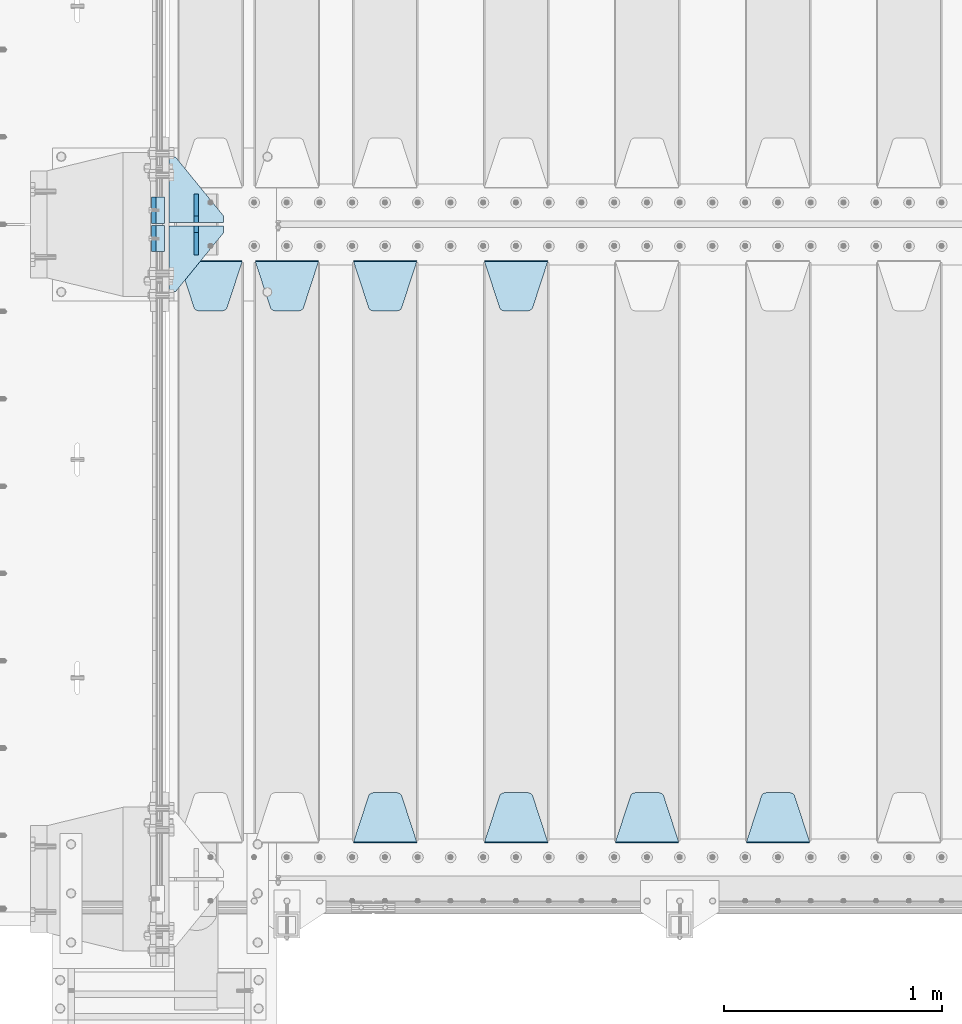
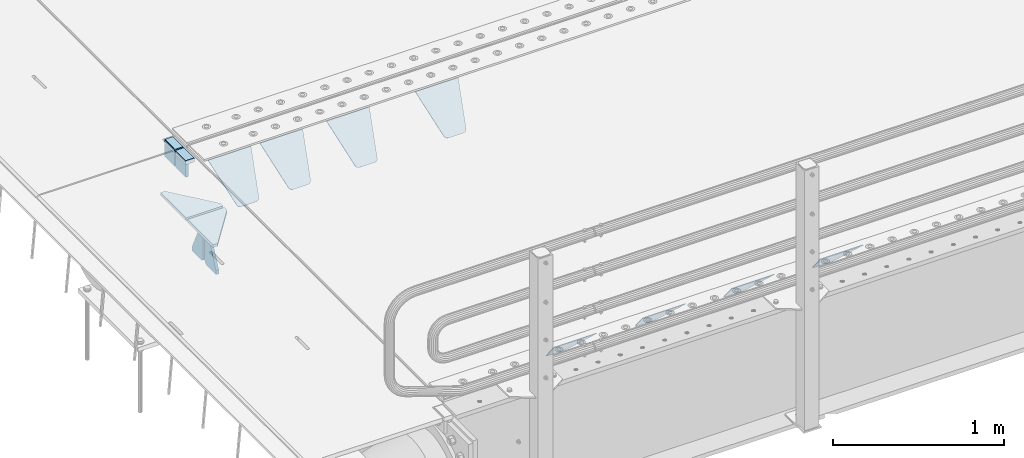
# One storey, part 191 of 240: 16 plates.
"""IFC2X3 building model written with IfcOpenShell, lengths in millimetres."""

from ifc_helpers import new_model, si_unit, frame, origin_with_axes, place, context, subcontext, project, spatial, faceted_brep, material, type_object, element, save


model = new_model("IFC2X3")

# Units and contexts
model_context = context("Model", 3, precision=1e-05, world=origin_with_axes())
body_context = subcontext(model_context, "Body", "Model", "MODEL_VIEW")
ifc_project = project(units=[si_unit("LENGTHUNIT", "METRE", prefix="MILLI"), si_unit("AREAUNIT", "SQUARE_METRE"), si_unit("VOLUMEUNIT", "CUBIC_METRE"), si_unit("MASSUNIT", "GRAM", prefix="KILO"), si_unit("TIMEUNIT", "SECOND"), si_unit("PLANEANGLEUNIT", "RADIAN"), si_unit("SOLIDANGLEUNIT", "STERADIAN"), si_unit("THERMODYNAMICTEMPERATUREUNIT", "DEGREE_CELSIUS"), si_unit("LUMINOUSINTENSITYUNIT", "LUMEN")], contexts=[model_context])

# Site, building, storey
site_placement = place(None, origin_with_axes())
site = spatial("IfcSite", under=ifc_project, at=site_placement, CompositionType="ELEMENT")
building_placement = place(site_placement, origin_with_axes())
building = spatial("IfcBuilding", under=site, at=building_placement, Name="Standard", CompositionType="ELEMENT")
storey_placement = place(building_placement, origin_with_axes())
storey = spatial("IfcBuildingStorey", under=building, at=storey_placement, Name="Undefined", CompositionType="ELEMENT", Elevation=0.0)

# Plates
ifc_material_1 = material()
plate_type_1 = type_object("IfcPlateType", PredefinedType="NOTDEFINED")
plate_1_placement = place(storey_placement, frame((42440.0, 26935.0, -16.0001127571065), z_axis=(-1.0, 0.0, 0.0), x_axis=(0.0, 0.0, 1.0)))
element("IfcPlate", 1, at=plate_1_placement, inside=storey, type_object=plate_type_1, material=ifc_material_1, context=body_context, shape_type="Brep", body=[
    faceted_brep([(3.5527136788005e-15, -60.0, 0.0), (2.49929144047201e-09, -60.0, 60.0), (2.49929144047201e-09, 60.0000000000036, 60.0), (0.0, 60.0000000000036, -7.27595761418343e-12), (25.0146748218828, -59.9999999999964, 60.0), (25.0146748218828, 60.0, 60.0), (26.5597449794466, -60.0, 59.7552873949098), (26.5597449794466, 60.0000000000036, 59.7552873949098), (27.9535758796897, -59.9999999999964, 59.0451032832789), (27.9535758796897, 60.0000000000036, 59.0451032832789), (29.0597323263517, -60.0, 57.9389640667287), (29.0597323263517, 60.0, 57.9389640667287), (29.7699381491534, -59.9999999999964, 56.5451442289705), (29.7699381491534, 60.0000000000036, 56.5451442289705), (30.0146748212763, -60.0, 55.0000778834001), (30.0146748212763, 60.0, 55.0000778834001), (30.0154536553013, -59.9999999999964, 5.00007788340736), (30.0154536553013, 60.0000000000036, 5.00007788340736), (29.7707554908505, -59.9999999999964, 3.45497428546514), (29.7707554908505, 60.0000000000036, 3.45497428546514), (29.0605660948355, -59.9999999999964, 2.06111154406972), (29.0605660948355, 60.0000000000036, 2.06111154406972), (27.9544051209123, -59.9999999999964, 0.954933339693525), (27.9544051209123, 60.0000000000036, 0.954933339693525), (26.5605534420796, -59.9999999999964, 0.244722232011554), (26.5605534420796, 60.0000000000036, 0.244722232011554), (25.0154536559091, -60.0, 7.27595761418343e-12), (25.0154536559091, 60.0, 7.27595761418343e-12)], [[[0, 1, 2, 3]], [[1, 4, 5, 2]], [[4, 6, 7, 5]], [[6, 8, 9, 7]], [[8, 10, 11, 9]], [[10, 12, 13, 11]], [[12, 14, 15, 13]], [[14, 16, 17, 15]], [[16, 18, 19, 17]], [[18, 20, 21, 19]], [[20, 22, 23, 21]], [[22, 24, 25, 23]], [[24, 26, 27, 25]], [[26, 0, 3, 27]], [[5, 7, 9, 11, 13, 15, 17, 19, 21, 23, 25, 27, 3, 2]], [[26, 24, 22, 20, 18, 16, 14, 12, 10, 8, 6, 4, 1, 0]]]),
])
plate_2_placement = place(storey_placement, frame((42439.99999994, 27065.0000004521, -16.0146144413882), z_axis=(-1.0, 0.0, 0.0), x_axis=(0.0, -4.95099997756316e-06, 0.999999999987744)))
element("IfcPlate", 2, at=plate_2_placement, inside=storey, type_object=plate_type_1, material=ifc_material_1, context=body_context, shape_type="Brep", body=[
    faceted_brep([(3.5527136788005e-15, -60.0, 0.0), (-0.000933120085687023, -60.0000000000036, 60.0), (-0.000933120085687023, 60.0, 59.9999999999927), (0.0, 60.0000000000036, -7.27595761418343e-12), (24.9991450303709, -60.0, 60.0), (24.9991450303709, 59.9999999999964, 59.9999999999927), (26.544215218168, -60.0000000000036, 59.7552873850873), (26.544215218168, 60.0, 59.75528738508), (27.9380461396139, -60.0, 59.0451032459096), (27.9380461396139, 60.0, 59.0451032459096), (29.0442025908961, -60.0, 57.9389639895744), (29.0442025908961, 60.0, 57.9389639895744), (29.7544083969366, -60.0, 56.5451441080368), (29.7544083969366, 60.0000000000036, 56.5451441080295), (29.9991450297669, -60.0000000000036, 55.0000777244568), (29.9991450297669, 60.0, 55.0000777244495), (29.999922274335, -60.0, 5.00007772445679), (29.999922274335, 60.0, 5.00007772444951), (29.7552240705896, -60.0000000000036, 3.45497416452417), (29.7552240705896, 60.0, 3.45497416452417), (29.0450346578116, -60.0, 2.06111146690819), (29.0450346578116, 60.0, 2.06111146690819), (27.9388736885073, -60.0, 0.954933302316931), (27.9388736885072, 59.9999999999964, 0.954933302316931), (26.5450220308766, -60.0000000000036, 0.244722222181736), (26.5450220308766, 60.0, 0.244722222181736), (24.9999222749392, -59.9999999999964, 0.0), (24.9999222749392, 60.0, -7.27595761418343e-12)], [[[0, 1, 2, 3]], [[1, 4, 5, 2]], [[4, 6, 7, 5]], [[6, 8, 9, 7]], [[8, 10, 11, 9]], [[10, 12, 13, 11]], [[12, 14, 15, 13]], [[14, 16, 17, 15]], [[16, 18, 19, 17]], [[18, 20, 21, 19]], [[20, 22, 23, 21]], [[22, 24, 25, 23]], [[24, 26, 27, 25]], [[26, 0, 3, 27]], [[5, 7, 9, 11, 13, 15, 17, 19, 21, 23, 25, 27, 3, 2]], [[26, 24, 22, 20, 18, 16, 14, 12, 10, 8, 6, 4, 1, 0]]]),
])
ifc_material_2 = material(Name="STEEL/S355N")
plate_type_2 = type_object("IfcPlateType", PredefinedType="NOTDEFINED")
plate_3_placement = place(storey_placement, frame((42390.0, 26995.0000855346, -105.984447297247), z_axis=(0.0, -1.0, 0.0), x_axis=(0.0, 0.0, 1.0)))
element("IfcPlate", 3, at=plate_3_placement, inside=storey, type_object=plate_type_2, material=ifc_material_2, context=body_context, shape_type="Brep", body=[
    faceted_brep([(0.0, -10.0, 0.0), (5.70725632087488e-07, -10.0, 119.999999999993), (5.70725632087488e-07, 10.0, 119.999999999993), (0.0, 10.0, 0.0), (89.9845046997066, -10.0, 119.999999999996), (89.9845046997066, 10.0, 119.999999999996), (89.9843902587891, -10.0, 6.18456397205591e-11), (89.9843902587891, 10.0, 6.18456397205591e-11)], [[[0, 1, 2, 3]], [[1, 4, 5, 2]], [[4, 6, 7, 5]], [[6, 0, 3, 7]], [[5, 7, 3, 2]], [[6, 4, 1, 0]]]),
])
plate_4_placement = place(storey_placement, frame((42390.0, 27125.000446002, -106.014939471591), z_axis=(0.0, -0.999999999987744, -4.95099999993769e-06), x_axis=(0.0, -4.95099997756316e-06, 0.999999999987744)))
element("IfcPlate", 4, at=plate_4_placement, inside=storey, type_object=plate_type_2, material=ifc_material_2, context=body_context, shape_type="Brep", body=[
    faceted_brep([(0.0, -10.0, 0.0), (5.70725632087488e-07, -10.0, 119.999999999993), (5.70725632087488e-07, 10.0, 119.999999999993), (0.0, 10.0, 0.0), (89.9999999999979, -10.0, 120.0), (89.9999999999979, 10.0, 120.0), (90.0, -10.0, 1.09139364212751e-11), (90.0, 10.0, 1.09139364212751e-11)], [[[0, 1, 2, 3]], [[1, 4, 5, 2]], [[4, 6, 7, 5]], [[6, 0, 3, 7]], [[5, 7, 3, 2]], [[6, 4, 1, 0]]]),
])
plate_type_3 = type_object("IfcPlateType", PredefinedType="NOTDEFINED")
plate_5_placement = place(storey_placement, frame((45395.0, 24168.232233047, -1.76776695296758), z_axis=(0.0, 0.707106781186547, -0.707106781186548), x_axis=(-1.0, 0.0, 0.0)))
element("IfcPlate", 5, at=plate_5_placement, inside=storey, type_object=plate_type_3, material=ifc_material_2, context=body_context, shape_type="Brep", body=[
    faceted_brep([(0.0, -2.5, 0.0), (69.345504679477, -2.50000000000364, 300.171731424827), (69.345504679477, 2.49999999999636, 300.171731424827), (0.0, 2.5, 0.0), (70.927406119954, -2.50000000000364, 304.897442415397), (70.927406119954, 2.49999999999636, 304.897442415397), (73.3818627772271, -2.50000000000728, 309.234538108525), (73.3818627772271, 2.49999999999636, 309.234538108529), (76.6187032999587, -2.50000000000728, 313.023683126099), (76.6187032999587, 2.49999999999636, 313.023683126103), (80.5190132705029, -2.50000000000364, 316.125672595368), (80.5190132705029, 2.49999999999636, 316.125672595368), (84.9395038596849, -2.50000000000364, 318.426546230472), (84.9395038596849, 2.49999999999636, 318.426546230472), (89.7177759439219, -2.5, 319.841774983277), (89.7177759439219, 2.49999999999636, 319.841774983273), (94.6782862926484, -2.50000000000364, 320.319366455074), (94.6782862926484, 2.49999999999636, 320.319366455074), (195.321713707352, -2.50000000000364, 320.319366455074), (195.321713707352, 2.49999999999636, 320.319366455074), (200.282224056078, -2.50000000000364, 319.841774983273), (200.282224056078, 2.49999999999636, 319.841774983273), (205.060496140315, -2.50000000000364, 318.426546230472), (205.060496140315, 2.49999999999636, 318.426546230472), (209.480986729497, -2.50000000000364, 316.125672595368), (209.480986729497, 2.49999999999636, 316.125672595368), (213.381296700041, -2.50000000000728, 313.023683126099), (213.381296700041, 2.49999999999272, 313.023683126099), (216.618137222766, -2.50000000000364, 309.234538108522), (216.618137222766, 2.49999999999636, 309.234538108522), (219.072593880039, -2.50000000000364, 304.897442415397), (219.072593880039, 2.49999999999636, 304.897442415397), (220.654495320523, -2.50000000000364, 300.171731424827), (220.654495320523, 2.49999999999636, 300.171731424827), (290.0, -2.50000000000364, -3.63797880709171e-12), (290.0, 2.49999999999636, -3.63797880709171e-12)], [[[0, 1, 2, 3]], [[1, 4, 5, 2]], [[4, 6, 7, 5]], [[6, 8, 9, 7]], [[8, 10, 11, 9]], [[10, 12, 13, 11]], [[12, 14, 15, 13]], [[14, 16, 17, 15]], [[16, 18, 19, 17]], [[18, 20, 21, 19]], [[20, 22, 23, 21]], [[22, 24, 25, 23]], [[24, 26, 27, 25]], [[26, 28, 29, 27]], [[28, 30, 31, 29]], [[30, 32, 33, 31]], [[32, 34, 35, 33]], [[34, 0, 3, 35]], [[5, 7, 9, 11, 13, 15, 17, 19, 21, 23, 25, 27, 29, 31, 33, 35, 3, 2]], [[34, 32, 30, 28, 26, 24, 22, 20, 18, 16, 14, 12, 10, 8, 6, 4, 1, 0]]]),
])
plate_6_placement = place(storey_placement, frame((44795.0, 24168.232233047, -1.76776695296758), z_axis=(0.0, 0.707106781186547, -0.707106781186548), x_axis=(-1.0, 0.0, 0.0)))
element("IfcPlate", 6, at=plate_6_placement, inside=storey, type_object=plate_type_3, material=ifc_material_2, context=body_context, shape_type="Brep", body=[
    faceted_brep([(0.0, -2.5, 0.0), (69.345504679477, -2.50000000000364, 300.171731424827), (69.345504679477, 2.49999999999636, 300.171731424827), (0.0, 2.5, 0.0), (70.927406119954, -2.50000000000364, 304.897442415397), (70.927406119954, 2.49999999999636, 304.897442415397), (73.3818627772271, -2.50000000000728, 309.234538108525), (73.3818627772271, 2.49999999999636, 309.234538108529), (76.6187032999587, -2.50000000000728, 313.023683126099), (76.6187032999587, 2.49999999999636, 313.023683126103), (80.5190132705029, -2.50000000000364, 316.125672595368), (80.5190132705029, 2.49999999999636, 316.125672595368), (84.9395038596849, -2.50000000000364, 318.426546230472), (84.9395038596849, 2.49999999999636, 318.426546230472), (89.7177759439219, -2.5, 319.841774983277), (89.7177759439219, 2.49999999999636, 319.841774983273), (94.6782862926484, -2.50000000000364, 320.319366455074), (94.6782862926484, 2.49999999999636, 320.319366455074), (195.321713707352, -2.50000000000364, 320.319366455074), (195.321713707352, 2.49999999999636, 320.319366455074), (200.282224056078, -2.50000000000364, 319.841774983273), (200.282224056078, 2.49999999999636, 319.841774983273), (205.060496140315, -2.50000000000364, 318.426546230472), (205.060496140315, 2.49999999999636, 318.426546230472), (209.480986729497, -2.50000000000364, 316.125672595368), (209.480986729497, 2.49999999999636, 316.125672595368), (213.381296700041, -2.50000000000728, 313.023683126099), (213.381296700041, 2.49999999999272, 313.023683126099), (216.618137222766, -2.50000000000364, 309.234538108522), (216.618137222766, 2.49999999999636, 309.234538108522), (219.072593880039, -2.50000000000364, 304.897442415397), (219.072593880039, 2.49999999999636, 304.897442415397), (220.654495320523, -2.50000000000364, 300.171731424827), (220.654495320523, 2.49999999999636, 300.171731424827), (290.0, -2.50000000000364, -3.63797880709171e-12), (290.0, 2.49999999999636, -3.63797880709171e-12)], [[[0, 1, 2, 3]], [[1, 4, 5, 2]], [[4, 6, 7, 5]], [[6, 8, 9, 7]], [[8, 10, 11, 9]], [[10, 12, 13, 11]], [[12, 14, 15, 13]], [[14, 16, 17, 15]], [[16, 18, 19, 17]], [[18, 20, 21, 19]], [[20, 22, 23, 21]], [[22, 24, 25, 23]], [[24, 26, 27, 25]], [[26, 28, 29, 27]], [[28, 30, 31, 29]], [[30, 32, 33, 31]], [[32, 34, 35, 33]], [[34, 0, 3, 35]], [[5, 7, 9, 11, 13, 15, 17, 19, 21, 23, 25, 27, 29, 31, 33, 35, 3, 2]], [[34, 32, 30, 28, 26, 24, 22, 20, 18, 16, 14, 12, 10, 8, 6, 4, 1, 0]]]),
])
plate_7_placement = place(storey_placement, frame((43905.0, 26831.767766956, -1.76776695296758), z_axis=(0.0, -0.707106781186547, -0.707106781186548), x_axis=(1.0, 0.0, 0.0)))
element("IfcPlate", 7, at=plate_7_placement, inside=storey, type_object=plate_type_3, material=ifc_material_2, context=body_context, shape_type="Brep", body=[
    faceted_brep([(0.0, -2.5, 0.0), (69.345504679477, -2.50000000000364, 300.171731424827), (69.345504679477, 2.49999999999636, 300.171731424827), (0.0, 2.5, 0.0), (70.927406119954, -2.50000000000364, 304.897442415397), (70.927406119954, 2.49999999999636, 304.897442415397), (73.3818627772271, -2.50000000000728, 309.234538108525), (73.3818627772271, 2.49999999999636, 309.234538108529), (76.6187032999587, -2.50000000000728, 313.023683126099), (76.6187032999587, 2.49999999999636, 313.023683126103), (80.5190132705029, -2.50000000000364, 316.125672595368), (80.5190132705029, 2.49999999999636, 316.125672595368), (84.9395038596849, -2.50000000000364, 318.426546230472), (84.9395038596849, 2.49999999999636, 318.426546230472), (89.7177759439219, -2.5, 319.841774983277), (89.7177759439219, 2.49999999999636, 319.841774983273), (94.6782862926484, -2.50000000000364, 320.319366455074), (94.6782862926484, 2.49999999999636, 320.319366455074), (195.321713707352, -2.50000000000364, 320.319366455074), (195.321713707352, 2.49999999999636, 320.319366455074), (200.282224056078, -2.50000000000364, 319.841774983273), (200.282224056078, 2.49999999999636, 319.841774983273), (205.060496140315, -2.50000000000364, 318.426546230472), (205.060496140315, 2.49999999999636, 318.426546230472), (209.480986729497, -2.50000000000364, 316.125672595368), (209.480986729497, 2.49999999999636, 316.125672595368), (213.381296700041, -2.50000000000728, 313.023683126099), (213.381296700041, 2.49999999999272, 313.023683126099), (216.618137222766, -2.50000000000364, 309.234538108522), (216.618137222766, 2.49999999999636, 309.234538108522), (219.072593880039, -2.50000000000364, 304.897442415397), (219.072593880039, 2.49999999999636, 304.897442415397), (220.654495320523, -2.50000000000364, 300.171731424827), (220.654495320523, 2.49999999999636, 300.171731424827), (290.0, -2.50000000000364, -3.63797880709171e-12), (290.0, 2.49999999999636, -3.63797880709171e-12)], [[[0, 1, 2, 3]], [[1, 4, 5, 2]], [[4, 6, 7, 5]], [[6, 8, 9, 7]], [[8, 10, 11, 9]], [[10, 12, 13, 11]], [[12, 14, 15, 13]], [[14, 16, 17, 15]], [[16, 18, 19, 17]], [[18, 20, 21, 19]], [[20, 22, 23, 21]], [[22, 24, 25, 23]], [[24, 26, 27, 25]], [[26, 28, 29, 27]], [[28, 30, 31, 29]], [[30, 32, 33, 31]], [[32, 34, 35, 33]], [[34, 0, 3, 35]], [[5, 7, 9, 11, 13, 15, 17, 19, 21, 23, 25, 27, 29, 31, 33, 35, 3, 2]], [[34, 32, 30, 28, 26, 24, 22, 20, 18, 16, 14, 12, 10, 8, 6, 4, 1, 0]]]),
])
plate_8_placement = place(storey_placement, frame((44195.0, 24168.232233047, -1.76776695296758), z_axis=(0.0, 0.707106781186547, -0.707106781186548), x_axis=(-1.0, 0.0, 0.0)))
element("IfcPlate", 8, at=plate_8_placement, inside=storey, type_object=plate_type_3, material=ifc_material_2, context=body_context, shape_type="Brep", body=[
    faceted_brep([(0.0, -2.5, 0.0), (69.345504679477, -2.50000000000364, 300.171731424827), (69.345504679477, 2.49999999999636, 300.171731424827), (0.0, 2.5, 0.0), (70.927406119954, -2.50000000000364, 304.897442415397), (70.927406119954, 2.49999999999636, 304.897442415397), (73.3818627772271, -2.50000000000728, 309.234538108525), (73.3818627772271, 2.49999999999636, 309.234538108529), (76.6187032999587, -2.50000000000728, 313.023683126099), (76.6187032999587, 2.49999999999636, 313.023683126103), (80.5190132705029, -2.50000000000364, 316.125672595368), (80.5190132705029, 2.49999999999636, 316.125672595368), (84.9395038596849, -2.50000000000364, 318.426546230472), (84.9395038596849, 2.49999999999636, 318.426546230472), (89.7177759439219, -2.5, 319.841774983277), (89.7177759439219, 2.49999999999636, 319.841774983273), (94.6782862926484, -2.50000000000364, 320.319366455074), (94.6782862926484, 2.49999999999636, 320.319366455074), (195.321713707352, -2.50000000000364, 320.319366455074), (195.321713707352, 2.49999999999636, 320.319366455074), (200.282224056078, -2.50000000000364, 319.841774983273), (200.282224056078, 2.49999999999636, 319.841774983273), (205.060496140315, -2.50000000000364, 318.426546230472), (205.060496140315, 2.49999999999636, 318.426546230472), (209.480986729497, -2.50000000000364, 316.125672595368), (209.480986729497, 2.49999999999636, 316.125672595368), (213.381296700041, -2.50000000000728, 313.023683126099), (213.381296700041, 2.49999999999272, 313.023683126099), (216.618137222766, -2.50000000000364, 309.234538108522), (216.618137222766, 2.49999999999636, 309.234538108522), (219.072593880039, -2.50000000000364, 304.897442415397), (219.072593880039, 2.49999999999636, 304.897442415397), (220.654495320523, -2.50000000000364, 300.171731424827), (220.654495320523, 2.49999999999636, 300.171731424827), (290.0, -2.50000000000364, -3.63797880709171e-12), (290.0, 2.49999999999636, -3.63797880709171e-12)], [[[0, 1, 2, 3]], [[1, 4, 5, 2]], [[4, 6, 7, 5]], [[6, 8, 9, 7]], [[8, 10, 11, 9]], [[10, 12, 13, 11]], [[12, 14, 15, 13]], [[14, 16, 17, 15]], [[16, 18, 19, 17]], [[18, 20, 21, 19]], [[20, 22, 23, 21]], [[22, 24, 25, 23]], [[24, 26, 27, 25]], [[26, 28, 29, 27]], [[28, 30, 31, 29]], [[30, 32, 33, 31]], [[32, 34, 35, 33]], [[34, 0, 3, 35]], [[5, 7, 9, 11, 13, 15, 17, 19, 21, 23, 25, 27, 29, 31, 33, 35, 3, 2]], [[34, 32, 30, 28, 26, 24, 22, 20, 18, 16, 14, 12, 10, 8, 6, 4, 1, 0]]]),
])
plate_9_placement = place(storey_placement, frame((43305.0, 26831.767766956, -1.76776695296758), z_axis=(0.0, -0.707106781186547, -0.707106781186548), x_axis=(1.0, 0.0, 0.0)))
element("IfcPlate", 9, at=plate_9_placement, inside=storey, type_object=plate_type_3, material=ifc_material_2, context=body_context, shape_type="Brep", body=[
    faceted_brep([(0.0, -2.5, 0.0), (69.345504679477, -2.50000000000364, 300.171731424827), (69.345504679477, 2.49999999999636, 300.171731424827), (0.0, 2.5, 0.0), (70.927406119954, -2.50000000000364, 304.897442415397), (70.927406119954, 2.49999999999636, 304.897442415397), (73.3818627772271, -2.50000000000728, 309.234538108525), (73.3818627772271, 2.49999999999636, 309.234538108529), (76.6187032999587, -2.50000000000728, 313.023683126099), (76.6187032999587, 2.49999999999636, 313.023683126103), (80.5190132705029, -2.50000000000364, 316.125672595368), (80.5190132705029, 2.49999999999636, 316.125672595368), (84.9395038596849, -2.50000000000364, 318.426546230472), (84.9395038596849, 2.49999999999636, 318.426546230472), (89.7177759439219, -2.5, 319.841774983277), (89.7177759439219, 2.49999999999636, 319.841774983273), (94.6782862926484, -2.50000000000364, 320.319366455074), (94.6782862926484, 2.49999999999636, 320.319366455074), (195.321713707352, -2.50000000000364, 320.319366455074), (195.321713707352, 2.49999999999636, 320.319366455074), (200.282224056078, -2.50000000000364, 319.841774983273), (200.282224056078, 2.49999999999636, 319.841774983273), (205.060496140315, -2.50000000000364, 318.426546230472), (205.060496140315, 2.49999999999636, 318.426546230472), (209.480986729497, -2.50000000000364, 316.125672595368), (209.480986729497, 2.49999999999636, 316.125672595368), (213.381296700041, -2.50000000000728, 313.023683126099), (213.381296700041, 2.49999999999272, 313.023683126099), (216.618137222766, -2.50000000000364, 309.234538108522), (216.618137222766, 2.49999999999636, 309.234538108522), (219.072593880039, -2.50000000000364, 304.897442415397), (219.072593880039, 2.49999999999636, 304.897442415397), (220.654495320523, -2.50000000000364, 300.171731424827), (220.654495320523, 2.49999999999636, 300.171731424827), (290.0, -2.50000000000364, -3.63797880709171e-12), (290.0, 2.49999999999636, -3.63797880709171e-12)], [[[0, 1, 2, 3]], [[1, 4, 5, 2]], [[4, 6, 7, 5]], [[6, 8, 9, 7]], [[8, 10, 11, 9]], [[10, 12, 13, 11]], [[12, 14, 15, 13]], [[14, 16, 17, 15]], [[16, 18, 19, 17]], [[18, 20, 21, 19]], [[20, 22, 23, 21]], [[22, 24, 25, 23]], [[24, 26, 27, 25]], [[26, 28, 29, 27]], [[28, 30, 31, 29]], [[30, 32, 33, 31]], [[32, 34, 35, 33]], [[34, 0, 3, 35]], [[5, 7, 9, 11, 13, 15, 17, 19, 21, 23, 25, 27, 29, 31, 33, 35, 3, 2]], [[34, 32, 30, 28, 26, 24, 22, 20, 18, 16, 14, 12, 10, 8, 6, 4, 1, 0]]]),
])
plate_10_placement = place(storey_placement, frame((43595.0, 24168.232233047, -1.76776695296758), z_axis=(0.0, 0.707106781186547, -0.707106781186548), x_axis=(-1.0, 0.0, 0.0)))
element("IfcPlate", 10, at=plate_10_placement, inside=storey, type_object=plate_type_3, material=ifc_material_2, context=body_context, shape_type="Brep", body=[
    faceted_brep([(0.0, -2.5, 0.0), (69.345504679477, -2.50000000000364, 300.171731424827), (69.345504679477, 2.49999999999636, 300.171731424827), (0.0, 2.5, 0.0), (70.927406119954, -2.50000000000364, 304.897442415397), (70.927406119954, 2.49999999999636, 304.897442415397), (73.3818627772271, -2.50000000000728, 309.234538108525), (73.3818627772271, 2.49999999999636, 309.234538108529), (76.6187032999587, -2.50000000000728, 313.023683126099), (76.6187032999587, 2.49999999999636, 313.023683126103), (80.5190132705029, -2.50000000000364, 316.125672595368), (80.5190132705029, 2.49999999999636, 316.125672595368), (84.9395038596849, -2.50000000000364, 318.426546230472), (84.9395038596849, 2.49999999999636, 318.426546230472), (89.7177759439219, -2.5, 319.841774983277), (89.7177759439219, 2.49999999999636, 319.841774983273), (94.6782862926484, -2.50000000000364, 320.319366455074), (94.6782862926484, 2.49999999999636, 320.319366455074), (195.321713707352, -2.50000000000364, 320.319366455074), (195.321713707352, 2.49999999999636, 320.319366455074), (200.282224056078, -2.50000000000364, 319.841774983273), (200.282224056078, 2.49999999999636, 319.841774983273), (205.060496140315, -2.50000000000364, 318.426546230472), (205.060496140315, 2.49999999999636, 318.426546230472), (209.480986729497, -2.50000000000364, 316.125672595368), (209.480986729497, 2.49999999999636, 316.125672595368), (213.381296700041, -2.50000000000728, 313.023683126099), (213.381296700041, 2.49999999999272, 313.023683126099), (216.618137222766, -2.50000000000364, 309.234538108522), (216.618137222766, 2.49999999999636, 309.234538108522), (219.072593880039, -2.50000000000364, 304.897442415397), (219.072593880039, 2.49999999999636, 304.897442415397), (220.654495320523, -2.50000000000364, 300.171731424827), (220.654495320523, 2.49999999999636, 300.171731424827), (290.0, -2.50000000000364, -3.63797880709171e-12), (290.0, 2.49999999999636, -3.63797880709171e-12)], [[[0, 1, 2, 3]], [[1, 4, 5, 2]], [[4, 6, 7, 5]], [[6, 8, 9, 7]], [[8, 10, 11, 9]], [[10, 12, 13, 11]], [[12, 14, 15, 13]], [[14, 16, 17, 15]], [[16, 18, 19, 17]], [[18, 20, 21, 19]], [[20, 22, 23, 21]], [[22, 24, 25, 23]], [[24, 26, 27, 25]], [[26, 28, 29, 27]], [[28, 30, 31, 29]], [[30, 32, 33, 31]], [[32, 34, 35, 33]], [[34, 0, 3, 35]], [[5, 7, 9, 11, 13, 15, 17, 19, 21, 23, 25, 27, 29, 31, 33, 35, 3, 2]], [[34, 32, 30, 28, 26, 24, 22, 20, 18, 16, 14, 12, 10, 8, 6, 4, 1, 0]]]),
])
plate_11_placement = place(storey_placement, frame((42855.0, 26831.767766956, -1.76776695296758), z_axis=(0.0, -0.707106781186547, -0.707106781186548), x_axis=(1.0, 0.0, 0.0)))
element("IfcPlate", 11, at=plate_11_placement, inside=storey, type_object=plate_type_3, material=ifc_material_2, context=body_context, shape_type="Brep", body=[
    faceted_brep([(0.0, -2.5, 0.0), (69.345504679477, -2.50000000000364, 300.171731424827), (69.345504679477, 2.49999999999636, 300.171731424827), (0.0, 2.5, 0.0), (70.927406119954, -2.50000000000364, 304.897442415397), (70.927406119954, 2.49999999999636, 304.897442415397), (73.3818627772271, -2.50000000000728, 309.234538108525), (73.3818627772271, 2.49999999999636, 309.234538108529), (76.6187032999587, -2.50000000000728, 313.023683126099), (76.6187032999587, 2.49999999999636, 313.023683126103), (80.5190132705029, -2.50000000000364, 316.125672595368), (80.5190132705029, 2.49999999999636, 316.125672595368), (84.9395038596849, -2.50000000000364, 318.426546230472), (84.9395038596849, 2.49999999999636, 318.426546230472), (89.7177759439219, -2.5, 319.841774983277), (89.7177759439219, 2.49999999999636, 319.841774983273), (94.6782862926484, -2.50000000000364, 320.319366455074), (94.6782862926484, 2.49999999999636, 320.319366455074), (195.321713707352, -2.50000000000364, 320.319366455074), (195.321713707352, 2.49999999999636, 320.319366455074), (200.282224056078, -2.50000000000364, 319.841774983273), (200.282224056078, 2.49999999999636, 319.841774983273), (205.060496140315, -2.50000000000364, 318.426546230472), (205.060496140315, 2.49999999999636, 318.426546230472), (209.480986729497, -2.50000000000364, 316.125672595368), (209.480986729497, 2.49999999999636, 316.125672595368), (213.381296700041, -2.50000000000728, 313.023683126099), (213.381296700041, 2.49999999999272, 313.023683126099), (216.618137222766, -2.50000000000364, 309.234538108522), (216.618137222766, 2.49999999999636, 309.234538108522), (219.072593880039, -2.50000000000364, 304.897442415397), (219.072593880039, 2.49999999999636, 304.897442415397), (220.654495320523, -2.50000000000364, 300.171731424827), (220.654495320523, 2.49999999999636, 300.171731424827), (290.0, -2.50000000000364, -3.63797880709171e-12), (290.0, 2.49999999999636, -3.63797880709171e-12)], [[[0, 1, 2, 3]], [[1, 4, 5, 2]], [[4, 6, 7, 5]], [[6, 8, 9, 7]], [[8, 10, 11, 9]], [[10, 12, 13, 11]], [[12, 14, 15, 13]], [[14, 16, 17, 15]], [[16, 18, 19, 17]], [[18, 20, 21, 19]], [[20, 22, 23, 21]], [[22, 24, 25, 23]], [[24, 26, 27, 25]], [[26, 28, 29, 27]], [[28, 30, 31, 29]], [[30, 32, 33, 31]], [[32, 34, 35, 33]], [[34, 0, 3, 35]], [[5, 7, 9, 11, 13, 15, 17, 19, 21, 23, 25, 27, 29, 31, 33, 35, 3, 2]], [[34, 32, 30, 28, 26, 24, 22, 20, 18, 16, 14, 12, 10, 8, 6, 4, 1, 0]]]),
])
plate_12_placement = place(storey_placement, frame((42505.0, 26831.767766956, -1.76776695296758), z_axis=(0.0, -0.707106781186547, -0.707106781186548), x_axis=(1.0, 0.0, 0.0)))
element("IfcPlate", 12, at=plate_12_placement, inside=storey, type_object=plate_type_3, material=ifc_material_2, context=body_context, shape_type="Brep", body=[
    faceted_brep([(0.0, -2.5, 0.0), (69.345504679477, -2.50000000000364, 300.171731424827), (69.345504679477, 2.49999999999636, 300.171731424827), (0.0, 2.5, 0.0), (70.927406119954, -2.50000000000364, 304.897442415397), (70.927406119954, 2.49999999999636, 304.897442415397), (73.3818627772271, -2.50000000000728, 309.234538108525), (73.3818627772271, 2.49999999999636, 309.234538108529), (76.6187032999587, -2.50000000000728, 313.023683126099), (76.6187032999587, 2.49999999999636, 313.023683126103), (80.5190132705029, -2.50000000000364, 316.125672595368), (80.5190132705029, 2.49999999999636, 316.125672595368), (84.9395038596849, -2.50000000000364, 318.426546230472), (84.9395038596849, 2.49999999999636, 318.426546230472), (89.7177759439219, -2.5, 319.841774983277), (89.7177759439219, 2.49999999999636, 319.841774983273), (94.6782862926484, -2.50000000000364, 320.319366455074), (94.6782862926484, 2.49999999999636, 320.319366455074), (195.321713707352, -2.50000000000364, 320.319366455074), (195.321713707352, 2.49999999999636, 320.319366455074), (200.282224056078, -2.50000000000364, 319.841774983273), (200.282224056078, 2.49999999999636, 319.841774983273), (205.060496140315, -2.50000000000364, 318.426546230472), (205.060496140315, 2.49999999999636, 318.426546230472), (209.480986729497, -2.50000000000364, 316.125672595368), (209.480986729497, 2.49999999999636, 316.125672595368), (213.381296700041, -2.50000000000728, 313.023683126099), (213.381296700041, 2.49999999999272, 313.023683126099), (216.618137222766, -2.50000000000364, 309.234538108522), (216.618137222766, 2.49999999999636, 309.234538108522), (219.072593880039, -2.50000000000364, 304.897442415397), (219.072593880039, 2.49999999999636, 304.897442415397), (220.654495320523, -2.50000000000364, 300.171731424827), (220.654495320523, 2.49999999999636, 300.171731424827), (290.0, -2.50000000000364, -3.63797880709171e-12), (290.0, 2.49999999999636, -3.63797880709171e-12)], [[[0, 1, 2, 3]], [[1, 4, 5, 2]], [[4, 6, 7, 5]], [[6, 8, 9, 7]], [[8, 10, 11, 9]], [[10, 12, 13, 11]], [[12, 14, 15, 13]], [[14, 16, 17, 15]], [[16, 18, 19, 17]], [[18, 20, 21, 19]], [[20, 22, 23, 21]], [[22, 24, 25, 23]], [[24, 26, 27, 25]], [[26, 28, 29, 27]], [[28, 30, 31, 29]], [[30, 32, 33, 31]], [[32, 34, 35, 33]], [[34, 0, 3, 35]], [[5, 7, 9, 11, 13, 15, 17, 19, 21, 23, 25, 27, 29, 31, 33, 35, 3, 2]], [[34, 32, 30, 28, 26, 24, 22, 20, 18, 16, 14, 12, 10, 8, 6, 4, 1, 0]]]),
])
plate_type_4 = type_object("IfcPlateType", PredefinedType="NOTDEFINED")
for number, where, z_axis, x_axis in (
    (13, (42710.0, 27008.0, -515.0), (0.0, 1.0, 0.0), (-1.0, 0.0, 0.0)),
    (14, (42710.0, 26992.0, -515.0), (0.0, -1.0, 0.0), (-1.0, 0.0, 0.0)),
):
    element("IfcPlate", number, at=place(storey_placement, frame(where, z_axis=z_axis, x_axis=x_axis)), inside=storey, type_object=plate_type_4, material=ifc_material_2, context=body_context, shape_type="Brep", body=[
        faceted_brep([(0.0, -10.0, 0.0), (0.0, -10.0, 30.0), (0.0, 10.0, 30.0), (0.0, 10.0, 0.0), (220.0, -10.0, 300.0), (220.0, 10.0, 300.0), (250.0, -10.0, 300.0), (250.0, 10.0, 300.0), (250.0, -10.0, 0.0), (250.0, 10.0, 0.0)], [[[0, 1, 2, 3]], [[1, 4, 5, 2]], [[4, 6, 7, 5]], [[6, 8, 9, 7]], [[8, 0, 3, 9]], [[5, 7, 9, 3, 2]], [[8, 6, 4, 1, 0]]]),
    ])
plate_type_5 = type_object("IfcPlateType", PredefinedType="NOTDEFINED")
for number, where, z_axis, x_axis in (
    (15, (42585.0, 26860.0, -860.0), (0.0, 0.0, 1.0), (0.0, 1.0, 0.0)),
    (16, (42585.0, 27140.0, -860.0), (0.0, 0.0, 1.0), (0.0, -1.0, 0.0)),
):
    element("IfcPlate", number, at=place(storey_placement, frame(where, z_axis=z_axis, x_axis=x_axis)), inside=storey, type_object=plate_type_5, material=ifc_material_2, context=body_context, shape_type="Brep", body=[
        faceted_brep([(0.0, -10.0, 0.0), (0.0, -10.0, 30.0), (0.0, 10.0, 30.0), (0.0, 10.0, 0.0), (102.0, -10.0, 250.0), (102.0, 10.0, 250.0), (132.0, -10.0, 250.0), (132.0, 10.0, 250.0), (132.0, -10.0, 30.0), (132.0, 10.0, 30.0), (131.544232590368, -10.0, 24.790554669992), (131.544232590368, 10.0, 24.790554669992), (130.190778623579, -10.0, 19.7393957002299), (130.190778623579, 10.0, 19.7393957002299), (127.980762113533, -10.0, 15.0), (127.980762113533, 10.0, 15.0), (124.98133329357, -10.0, 10.7163717094038), (124.98133329357, 10.0, 10.7163717094038), (121.283628290596, -10.0, 7.01866670643062), (121.283628290596, 10.0, 7.01866670643062), (117.0, -10.0, 4.01923788646684), (117.0, 10.0, 4.01923788646684), (112.260604299769, -10.0, 1.80922137642278), (112.260604299769, 10.0, 1.80922137642278), (107.209445330009, -10.0, 0.455767409633722), (107.209445330009, 10.0, 0.455767409633722), (102.0, -10.0, 0.0), (102.0, 10.0, 0.0)], [[[0, 1, 2, 3]], [[1, 4, 5, 2]], [[4, 6, 7, 5]], [[6, 8, 9, 7]], [[8, 10, 11, 9]], [[10, 12, 13, 11]], [[12, 14, 15, 13]], [[14, 16, 17, 15]], [[16, 18, 19, 17]], [[18, 20, 21, 19]], [[20, 22, 23, 21]], [[22, 24, 25, 23]], [[24, 26, 27, 25]], [[26, 0, 3, 27]], [[5, 7, 9, 11, 13, 15, 17, 19, 21, 23, 25, 27, 3, 2]], [[26, 24, 22, 20, 18, 16, 14, 12, 10, 8, 6, 4, 1, 0]]]),
    ])

save(model, "model.ifc")
